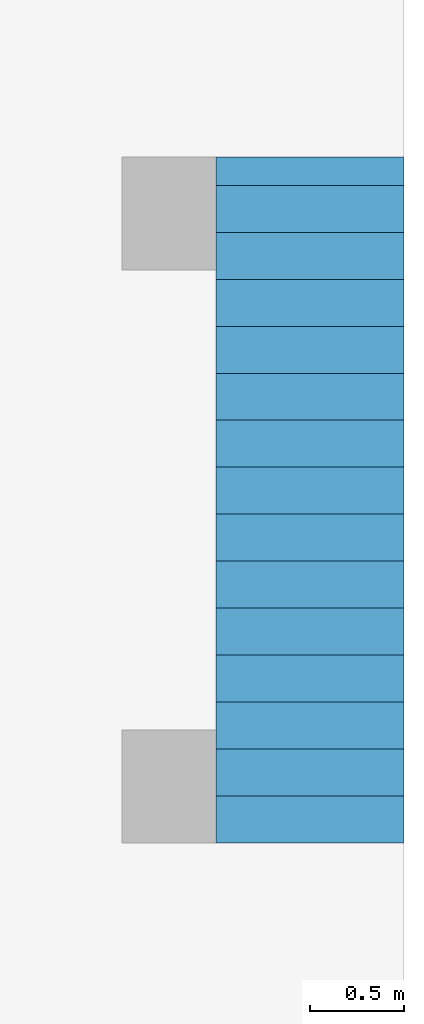
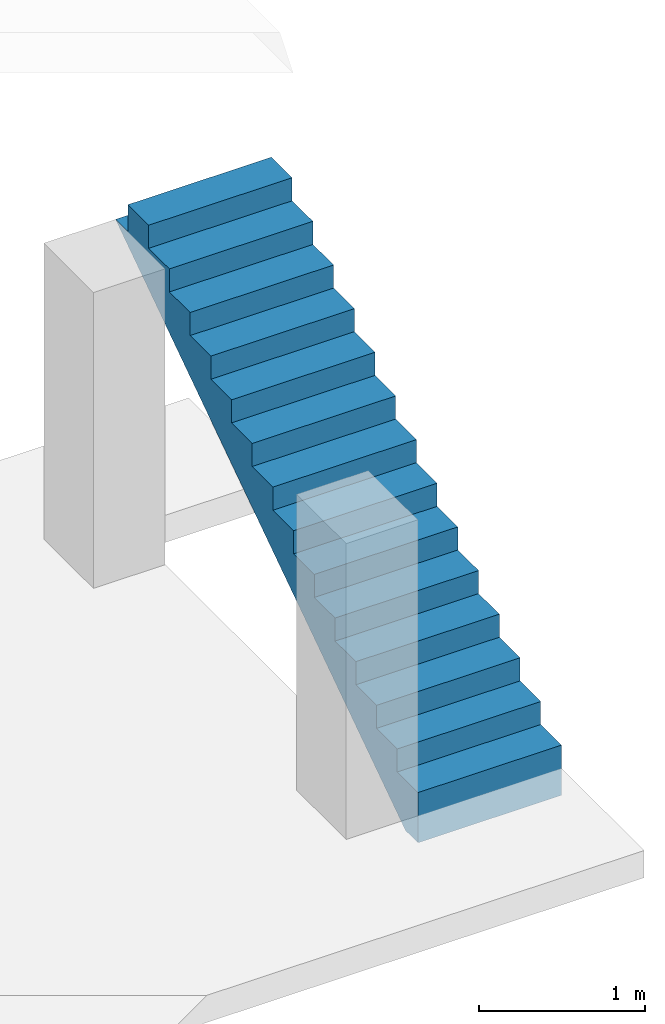
# One storey, part 2 of 2: 1 stair flight.
"""IFC4 building model written with IfcOpenShell, lengths in millimetres."""

from ifc_helpers import new_model, entity, si_unit, converted_unit, frame, origin_with_axes, origin_2d_with_axis, place, context, subcontext, project, spatial, polygons, element, save


model = new_model("IFC4")

# Units and contexts
model_context = context("Model", 3, precision=1e-05, world=origin_with_axes())
plan_context = context("Plan", 2, precision=1e-05, world=origin_2d_with_axis())
body_context = subcontext(model_context, "Body", "Model", "MODEL_VIEW")
ifc_project = project(units=[si_unit("VOLUMEUNIT", "CUBIC_METRE", prefix="MILLI"), si_unit("LENGTHUNIT", "METRE", prefix="MILLI"), converted_unit("PLANEANGLEUNIT", "degree", entity("IfcReal", 0.0174532925199433), si_unit("PLANEANGLEUNIT", "RADIAN"), dimensions=[0, 0, 0, 0, 0, 0, 0]), si_unit("AREAUNIT", "SQUARE_METRE", prefix="MILLI")], contexts=[model_context, plan_context])

# Site, building, storey
site_placement = place(None, origin_with_axes())
site = spatial("IfcSite", under=ifc_project, at=site_placement)
building_placement = place(site_placement, origin_with_axes())
building = spatial("IfcBuilding", under=site, at=building_placement, Name="Building")
storey_placement = place(building_placement, origin_with_axes())
storey = spatial("IfcBuildingStorey", under=building, at=storey_placement, Name="Storey")

# Stair flight
stair_flight_placement = place(storey_placement, frame((5000.0, 1000.0, 0.0), z_axis=(0.0, 0.0, 1.0), x_axis=(-4.37113882867379e-08, 1.0, 0.0)))
element("IfcStairFlight", 1, at=stair_flight_placement, inside=storey, Name="Stair", NumberOfRisers=7, NumberOfTreads=6, PredefinedType="STRAIGHT", RiserHeight=142.857142857143, TreadLength=250.0, context=body_context, shape_type="Tessellation", body=[
    polygons([(0.0, 0.0, 0.0), (0.0, 0.0, 169.999984741211), (249.999984741211, 0.0, 169.999984741211), (249.999984741211, 0.0, 339.999969482422), (499.999969482422, 0.0, 339.999969482422), (499.999969482422, 0.0, 509.999969482422), (749.999938964844, 0.0, 509.999969482422), (749.999938964844, 0.0, 679.999938964844), (999.999938964844, 0.0, 679.999938964844), (999.999938964844, 0.0, 850.0), (1249.99987792969, 0.0, 850.0), (1249.99987792969, 0.0, 1019.99993896484), (1499.99987792969, 0.0, 1019.99993896484), (1499.99987792969, 0.0, 1190.0), (1749.99987792969, 0.0, 1190.0), (1749.99987792969, 0.0, 1359.99987792969), (1999.99987792969, 0.0, 1359.99987792969), (1999.99987792969, 0.0, 1529.99987792969), (2249.99975585938, 0.0, 1529.99987792969), (2249.99975585938, 0.0, 1700.0), (2499.99975585938, 0.0, 1700.0), (2499.99975585938, 0.0, 1869.99987792969), (2749.99975585938, 0.0, 1869.99987792969), (2749.99975585938, 0.0, 2039.99987792969), (2999.99975585938, 0.0, 2039.99987792969), (2999.99975585938, 0.0, 2210.0), (3249.99975585938, 0.0, 2210.0), (3249.99975585938, 0.0, 2380.0), (3499.99975585938, 0.0, 2380.0), (3499.99975585938, 0.0, 2180.0), (3650.47680664062, 0.0, 2180.0), (150.476959228516, 0.0, -199.999984741211), (0.0, 0.0, -199.999984741211), (0.0, 999.999938964844, 169.999984741211), (249.999984741211, 999.999938964844, 169.999984741211), (249.999984741211, 999.999938964844, 339.999969482422), (499.999969482422, 999.999938964844, 339.999969482422), (499.999969482422, 999.999938964844, 509.999969482422), (749.999938964844, 999.999938964844, 509.999969482422), (749.999938964844, 999.999938964844, 679.999938964844), (999.999938964844, 999.999938964844, 679.999938964844), (999.999938964844, 999.999938964844, 850.0), (1249.99987792969, 999.999938964844, 850.0), (1249.99987792969, 999.999938964844, 1019.99993896484), (1499.99987792969, 999.999938964844, 1019.99993896484), (1499.99987792969, 999.999938964844, 1190.0), (1749.99987792969, 999.999938964844, 1190.0), (1749.99987792969, 999.999938964844, 1359.99987792969), (1999.99987792969, 999.999938964844, 1359.99987792969), (1999.99987792969, 999.999938964844, 1529.99987792969), (2249.99975585938, 999.999938964844, 1529.99987792969), (2249.99975585938, 999.999938964844, 1700.0), (2499.99975585938, 999.999938964844, 1700.0), (2499.99975585938, 999.999938964844, 1869.99987792969), (2749.99975585938, 999.999938964844, 1869.99987792969), (2749.99975585938, 999.999938964844, 2039.99987792969), (2999.99975585938, 999.999938964844, 2039.99987792969), (2999.99975585938, 999.999938964844, 2210.0), (3249.99975585938, 999.999938964844, 2210.0), (3249.99975585938, 999.999938964844, 2380.0), (3499.99975585938, 999.999938964844, 2380.0), (3499.99975585938, 999.999938964844, 2180.0), (3650.47680664062, 999.999938964844, 2180.0), (150.476959228516, 999.999938964844, -199.999984741211), (0.0, 999.999938964844, -199.999984741211), (0.0, 999.999938964844, 0.0)], [[[2, 1, 33, 32, 31, 30, 29, 28, 27, 26, 25, 24, 23, 22, 21, 20, 19, 18, 17, 16, 15, 14, 13, 12, 11, 10, 9, 8, 7, 6, 5, 4, 3]], [[34, 35, 36, 37, 38, 39, 40, 41, 42, 43, 44, 45, 46, 47, 48, 49, 50, 51, 52, 53, 54, 55, 56, 57, 58, 59, 60, 61, 62, 63, 64, 65, 66]], [[21, 22, 54, 53]], [[8, 9, 41, 40]], [[22, 23, 55, 54]], [[9, 10, 42, 41]], [[23, 24, 56, 55]], [[10, 11, 43, 42]], [[24, 25, 57, 56]], [[11, 12, 44, 43]], [[25, 26, 58, 57]], [[12, 13, 45, 44]], [[26, 27, 59, 58]], [[13, 14, 46, 45]], [[27, 28, 60, 59]], [[14, 15, 47, 46]], [[1, 2, 34, 66]], [[28, 29, 61, 60]], [[15, 16, 48, 47]], [[2, 3, 35, 34]], [[29, 30, 62, 61]], [[16, 17, 49, 48]], [[3, 4, 36, 35]], [[30, 31, 63, 62]], [[17, 18, 50, 49]], [[4, 5, 37, 36]], [[33, 1, 66, 65]], [[18, 19, 51, 50]], [[5, 6, 38, 37]], [[32, 33, 65, 64]], [[19, 20, 52, 51]], [[6, 7, 39, 38]], [[31, 32, 64, 63]], [[20, 21, 53, 52]], [[7, 8, 40, 39]]]),
])

save(model, "model.ifc")
